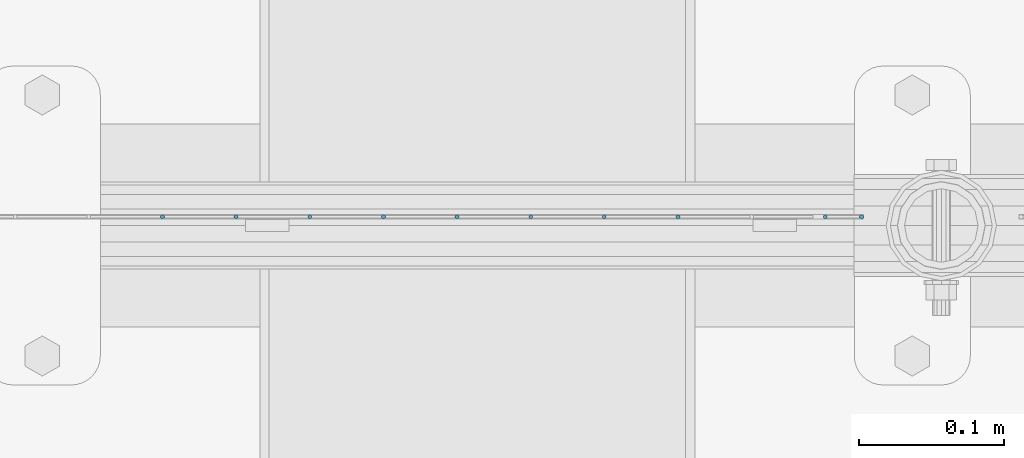
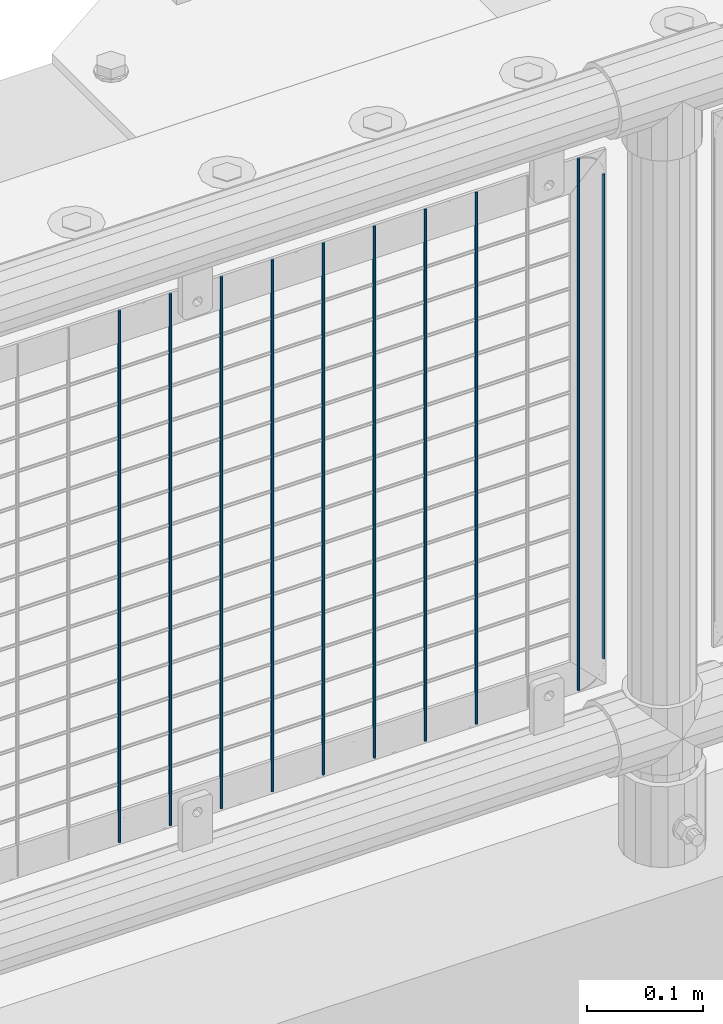
# One storey, part 78 of 270: 10 columns.
"""IFC2X3 building model written with IfcOpenShell, lengths in millimetres."""

from ifc_helpers import new_model, si_unit, frame, origin_with_axes, place, context, subcontext, project, spatial, faceted_brep, material, type_object, element, save


model = new_model("IFC2X3")

# Units and contexts
model_context = context("Model", 3, precision=1e-05, world=origin_with_axes())
body_context = subcontext(model_context, "Body", "Model", "MODEL_VIEW")
ifc_project = project(units=[si_unit("LENGTHUNIT", "METRE", prefix="MILLI"), si_unit("AREAUNIT", "SQUARE_METRE"), si_unit("VOLUMEUNIT", "CUBIC_METRE"), si_unit("MASSUNIT", "GRAM", prefix="KILO"), si_unit("TIMEUNIT", "SECOND"), si_unit("PLANEANGLEUNIT", "RADIAN"), si_unit("SOLIDANGLEUNIT", "STERADIAN"), si_unit("THERMODYNAMICTEMPERATUREUNIT", "DEGREE_CELSIUS"), si_unit("LUMINOUSINTENSITYUNIT", "LUMEN")], contexts=[model_context])

# Site, building, storey
site_placement = place(None, origin_with_axes())
site = spatial("IfcSite", under=ifc_project, at=site_placement, CompositionType="ELEMENT")
building_placement = place(site_placement, origin_with_axes())
building = spatial("IfcBuilding", under=site, at=building_placement, Name="Standard", CompositionType="ELEMENT")
storey_placement = place(building_placement, origin_with_axes())
storey = spatial("IfcBuildingStorey", under=building, at=storey_placement, Name="Undefined", CompositionType="ELEMENT", Elevation=0.0)

# Columns
ifc_material = material(Name="Misc_Undefined")
column_type = type_object("IfcColumnType", Name="D3", PredefinedType="NOTDEFINED")
for number, where, z_axis, x_axis in (
    (1, (5338.411, -16329.5, 353.02), (-1.0, 0.0, 0.0), (0.0, 0.0, 1.0)),
    (2, (5287.618, -16329.5, 353.02), (-1.0, 0.0, 0.0), (0.0, 0.0, 1.0)),
    (3, (5236.825, -16329.5, 353.02), (-1.0, 0.0, 0.0), (0.0, 0.0, 1.0)),
    (4, (5186.032, -16329.5, 353.02), (-1.0, 0.0, 0.0), (0.0, 0.0, 1.0)),
    (5, (5135.239, -16329.5, 353.02), (-1.0, 0.0, 0.0), (0.0, 0.0, 1.0)),
    (6, (5084.446, -16329.5, 353.02), (-1.0, 0.0, 0.0), (0.0, 0.0, 1.0)),
    (7, (5439.997, -16329.5, 353.02), (-1.0, 0.0, 0.0), (0.0, 0.0, 1.0)),
    (8, (5033.653, -16329.5, 353.02), (-1.0, 0.0, 0.0), (0.0, 0.0, 1.0)),
    (9, (4982.86, -16329.5, 353.02), (-1.0, 0.0, 0.0), (0.0, 0.0, 1.0)),
):
    element("IfcColumn", number, at=place(storey_placement, frame(where, z_axis=z_axis, x_axis=x_axis)), inside=storey, type_object=column_type, material=ifc_material, ObjectType="D3", context=body_context, shape_type="Brep", body=[
        faceted_brep([(0.0, -1.5, 0.0), (0.0, -0.75, -1.29903810567669), (560.0, -0.75, -1.29903810567703), (560.0, -1.5, 0.0), (0.0, 0.75, -1.29903810567669), (560.0, 0.75, -1.29903810567703), (0.0, 1.5, 0.0), (560.0, 1.5, 0.0), (0.0, 0.75, 1.29903810567669), (560.0, 0.75, 1.29903810567703), (0.0, -0.75, 1.29903810567669), (560.0, -0.75, 1.29903810567703)], [[[0, 1, 2, 3]], [[1, 4, 5, 2]], [[4, 6, 7, 5]], [[6, 8, 9, 7]], [[8, 10, 11, 9]], [[10, 0, 3, 11]], [[5, 7, 9, 11, 3, 2]], [[10, 8, 6, 4, 1, 0]]]),
    ])
column_placement = place(storey_placement, frame((5465.0, -16329.5, 378.02), z_axis=(-1.0, 0.0, 0.0), x_axis=(0.0, 0.0, 1.0)))
element("IfcColumn", 10, at=column_placement, inside=storey, type_object=column_type, material=ifc_material, ObjectType="D3", context=body_context, shape_type="Brep", body=[
    faceted_brep([(0.0, -1.5, 0.0), (0.0, -0.75, -1.29903810567669), (510.0, -0.75, -1.29903810567703), (510.0, -1.5, 0.0), (0.0, 0.75, -1.29903810567669), (510.0, 0.75, -1.29903810567703), (0.0, 1.5, 0.0), (510.0, 1.5, 0.0), (0.0, 0.75, 1.29903810567669), (510.0, 0.75, 1.29903810567703), (0.0, -0.75, 1.29903810567669), (510.0, -0.75, 1.29903810567703)], [[[0, 1, 2, 3]], [[1, 4, 5, 2]], [[4, 6, 7, 5]], [[6, 8, 9, 7]], [[8, 10, 11, 9]], [[10, 0, 3, 11]], [[5, 7, 9, 11, 3, 2]], [[10, 8, 6, 4, 1, 0]]]),
])

save(model, "model.ifc")
